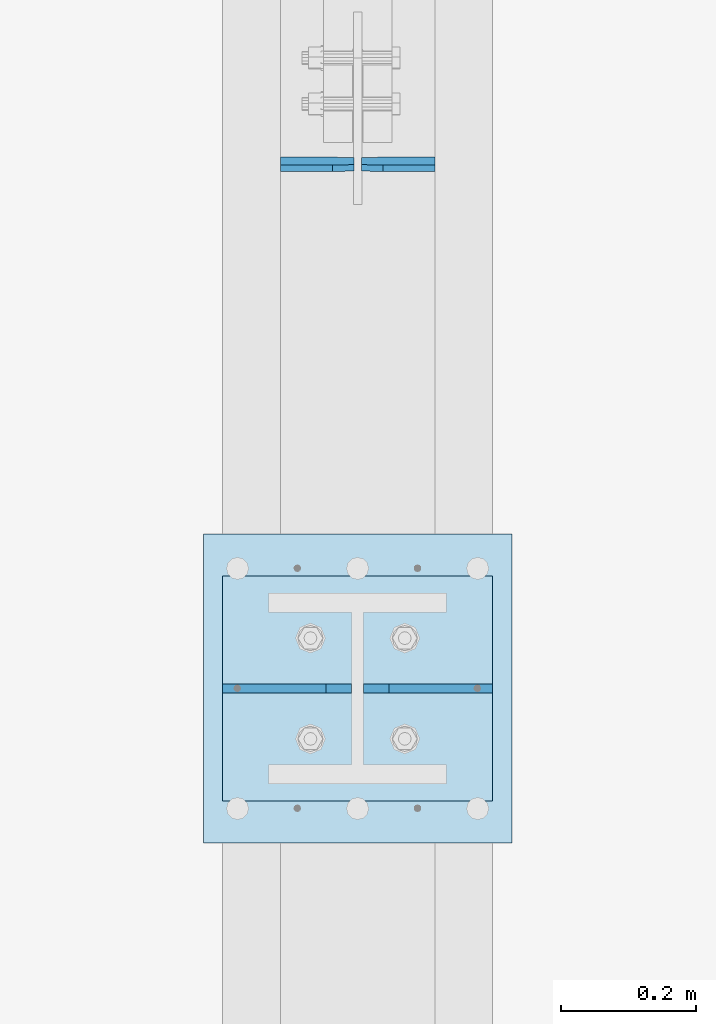
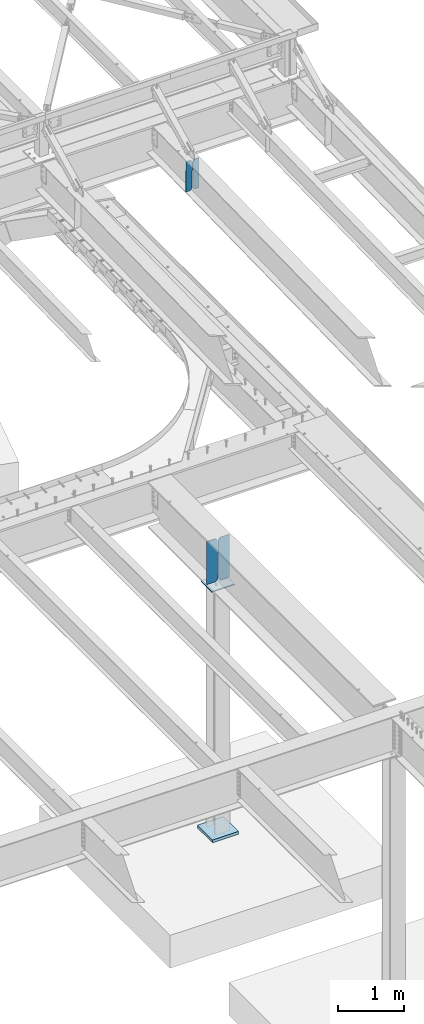
# One storey, part 1674 of 1763: 6 plates, 3 elements without a shape of their own.
"""IFC2X3 building model written with IfcOpenShell, lengths in millimetres."""

import ifcopenshell
import ifcopenshell.guid

model = None  # the IFC model being written
_history = None  # IfcOwnerHistory: only IFC2X3 demands one
_inside = {}  # id of a spatial element -> (the spatial element, [elements in it])
_under = {}  # id of a project, library or spatial element -> (it, [spatial elements below it])
_declared = {}  # id of a project -> (the project, [libraries it declares])
_typed = {}  # id of a type object -> (the type object, [elements of that type])
_made_of = {}  # id of a material, layer set ... -> (it, [elements and type objects made of it])


def new_model(schema):
    """Start an empty IFC model of exactly this schema.

    Asked for "IFC4X3", IfcOpenShell would pick the latest addendum, in which some entities
    have other attributes; the version numbers below select the first issue.
    IFC2X3 requires an IfcOwnerHistory on every rooted entity: one is made here for all.
    """
    global model, _history
    if schema == "IFC4X3":
        model = ifcopenshell.file(schema_version=(4, 3, 0, 0))
    else:
        model = ifcopenshell.file(schema=schema)
    _inside.clear()
    _under.clear()
    _declared.clear()
    _typed.clear()
    _made_of.clear()
    _history = None
    if model.schema == "IFC2X3":
        org = make("IfcOrganization", Name="unknown")
        user = make(
            "IfcPersonAndOrganization",
            ThePerson=make("IfcPerson", FamilyName="unknown"),
            TheOrganization=org,
        )
        app = make(
            "IfcApplication",
            ApplicationDeveloper=org,
            Version="unknown",
            ApplicationFullName="unknown",
            ApplicationIdentifier="unknown",
        )
        _history = make(
            "IfcOwnerHistory",
            OwningUser=user,
            OwningApplication=app,
            ChangeAction="ADDED",
            CreationDate=0,
        )
    return model


def make(cls, **values):
    """One entity of the class cls with the attributes given. An attribute that is None is left unset."""
    return model.create_entity(
        cls, **{name: value for name, value in values.items() if value is not None}
    )


def rooted(cls, **values):
    """An entity with a GlobalId (a new one), such as an element, a storey or a relation."""
    return make(cls, GlobalId=ifcopenshell.guid.new(), OwnerHistory=_history, **values)


def si_unit(unit_type, name, prefix=None):
    """IfcSIUnit, for example si_unit("LENGTHUNIT", "METRE", prefix="MILLI")."""
    return make("IfcSIUnit", UnitType=unit_type, Prefix=prefix, Name=name)


def assignment(units):
    """IfcUnitAssignment: the units of a project."""
    return None if units is None else make("IfcUnitAssignment", Units=units)


def point(xyz):
    """IfcCartesianPoint."""
    return None if xyz is None else make("IfcCartesianPoint", Coordinates=xyz)


def direction(xyz):
    """IfcDirection."""
    return None if xyz is None else make("IfcDirection", DirectionRatios=xyz)


def frame(location, z_axis=None, x_axis=None):
    """IfcAxis2Placement3D, a coordinate frame: its origin and axes. An axis left out is left unset."""
    return make(
        "IfcAxis2Placement3D",
        Location=point(location),
        Axis=direction(z_axis),
        RefDirection=direction(x_axis),
    )


def origin_with_axes():
    """The frame at (0, 0, 0) with the z axis (0, 0, 1) and the x axis (1, 0, 0) written out."""
    return frame((0.0, 0.0, 0.0), z_axis=(0.0, 0.0, 1.0), x_axis=(1.0, 0.0, 0.0))


def place(relative_to, where):
    """IfcLocalPlacement: puts the frame where relative to a parent placement (None: the world)."""
    return make(
        "IfcLocalPlacement", PlacementRelTo=relative_to, RelativePlacement=where
    )


def context(
    kind, dimensions, precision=None, world=None, true_north=None, identifier=None
):
    """IfcGeometricRepresentationContext, for example the 3D "Model" context."""
    return make(
        "IfcGeometricRepresentationContext",
        ContextIdentifier=identifier,
        ContextType=kind,
        CoordinateSpaceDimension=dimensions,
        Precision=precision,
        WorldCoordinateSystem=world,
        TrueNorth=true_north,
    )


def subcontext(parent, identifier, kind, view, scale=None):
    """IfcGeometricRepresentationSubContext, for example "Body" below "Model"."""
    return make(
        "IfcGeometricRepresentationSubContext",
        ContextIdentifier=identifier,
        ContextType=kind,
        ParentContext=parent,
        TargetScale=scale,
        TargetView=view,
    )


def project(units=None, contexts=None):
    """IfcProject with its units and contexts."""
    return rooted(
        "IfcProject",
        Name="project",
        RepresentationContexts=contexts,
        UnitsInContext=assignment(units),
    )


def spatial(cls, under=None, at=None, **own):
    """A site, building, storey or space (cls), placed at a placement, below another one or the project."""
    s = rooted(cls, ObjectPlacement=at, **own)
    if under is not None:
        _under.setdefault(under.id(), (under, []))[1].append(s)
    return s


def faces_of(points, faces, orient=None, outer=None):
    """IfcFace entities. A face is a list of loops; a loop is a list of indices into points, from 0.

    orient and outer hold one flag for each loop. By default every Orientation is true, the
    first loop of a face is its IfcFaceOuterBound and the others are IfcFaceBound.
    """
    made = []
    for i, loops in enumerate(faces):
        bounds = []
        for j, loop in enumerate(loops):
            is_outer = j == 0 if outer is None else outer[i][j]
            bounds.append(
                make(
                    "IfcFaceOuterBound" if is_outer else "IfcFaceBound",
                    Bound=make("IfcPolyLoop", Polygon=[points[k] for k in loop]),
                    Orientation=True if orient is None else orient[i][j],
                )
            )
        made.append(make("IfcFace", Bounds=bounds))
    return made


def faceted_brep(points, faces, orient=None, outer=None, voids=None):
    """IfcFacetedBrep: a solid bounded by flat faces; with voids (closed shells), ...WithVoids."""
    shared = [point(p) for p in points]
    hull = make("IfcClosedShell", CfsFaces=faces_of(shared, faces, orient, outer))
    if voids is None:
        return make("IfcFacetedBrep", Outer=hull)
    return make(
        "IfcFacetedBrepWithVoids",
        Outer=hull,
        Voids=[
            make(cls, CfsFaces=faces_of(shared, fs, o, b)) for cls, fs, o, b in voids
        ],
    )


def shape(context_of_items, identifier, shape_type, items):
    """IfcShapeRepresentation: the items that make up one representation, for example the "Body"."""
    return make(
        "IfcShapeRepresentation",
        ContextOfItems=context_of_items,
        RepresentationIdentifier=identifier,
        RepresentationType=shape_type,
        Items=items,
    )


def material(Name=None, Category=None):
    """IfcMaterial."""
    return make("IfcMaterial", Name=Name, Category=Category)


def made_of(thing, what):
    """Note that an element or type object is made of a material, layer set ...; save() writes the relation."""
    if what is not None:
        _made_of.setdefault(what.id(), (what, []))[1].append(thing)
    return thing


def type_object(cls, material=None, **own):
    """A type object (cls), such as IfcWallType, which elements share."""
    return made_of(rooted(cls, **own), material)


def element(
    cls,
    number,
    at=None,
    inside=None,
    cuts=None,
    type_object=None,
    material=None,
    context=None,
    identifier="Body",
    shape_type=None,
    held_by="IfcProductDefinitionShape",
    body=None,
    shapes=None,
    **own,
):
    """One element of the class cls, such as IfcWall. Its Tag is "e" and its number.

    at: its placement. inside: the storey or other place that contains it. cuts: it is an
    opening in that element (IfcRelVoidsElement). A single representation is given by context,
    identifier, shape_type and body (its items); several are given by shapes. held_by: the class
    of the entity that holds the representations. save() writes the other relations.
    """
    e = rooted(cls, Tag="e%d" % number, ObjectPlacement=at, **own)
    if body is not None:
        shapes = [shape(context, identifier, shape_type, body)]
    if shapes is not None:
        e.Representation = make(held_by, Representations=shapes)
    if inside is not None:
        _inside.setdefault(inside.id(), (inside, []))[1].append(e)
    if cuts is not None:
        rooted(
            "IfcRelVoidsElement", RelatingBuildingElement=cuts, RelatedOpeningElement=e
        )
    if type_object is not None:
        _typed.setdefault(type_object.id(), (type_object, []))[1].append(e)
    return made_of(e, material)


def aggregate(whole, parts):
    """IfcRelAggregates: a whole, such as a stair, and the parts it consists of."""
    return rooted("IfcRelAggregates", RelatingObject=whole, RelatedObjects=parts)


def save(model, path):
    """Write the relations noted so far, then the file.

    IfcRelAggregates (storeys below a building ...), IfcRelContainedInSpatialStructure (elements
    in a storey), IfcRelDefinesByType, IfcRelAssociatesMaterial and IfcRelDeclares: one each for
    every whole, place, type object, material and project.
    """
    for whole, parts in _under.values():
        aggregate(whole, parts)
    for where, things in _inside.values():
        rooted(
            "IfcRelContainedInSpatialStructure",
            RelatedElements=things,
            RelatingStructure=where,
        )
    for kind, things in _typed.values():
        rooted("IfcRelDefinesByType", RelatedObjects=things, RelatingType=kind)
    for what, things in _made_of.values():
        rooted("IfcRelAssociatesMaterial", RelatedObjects=things, RelatingMaterial=what)
    for by, libraries in _declared.values():
        rooted("IfcRelDeclares", RelatingContext=by, RelatedDefinitions=libraries)
    model.write(path)


model = new_model("IFC2X3")

# Units and contexts
model_context = context("Model", 3, precision=1e-05, world=origin_with_axes())
body_context = subcontext(model_context, "Body", "Model", "MODEL_VIEW")
ifc_project = project(units=[si_unit("LENGTHUNIT", "METRE", prefix="MILLI"), si_unit("AREAUNIT", "SQUARE_METRE"), si_unit("VOLUMEUNIT", "CUBIC_METRE"), si_unit("MASSUNIT", "GRAM", prefix="KILO"), si_unit("TIMEUNIT", "SECOND"), si_unit("PLANEANGLEUNIT", "RADIAN"), si_unit("SOLIDANGLEUNIT", "STERADIAN"), si_unit("THERMODYNAMICTEMPERATUREUNIT", "DEGREE_CELSIUS"), si_unit("LUMINOUSINTENSITYUNIT", "LUMEN")], contexts=[model_context])

# Site, building, storey
site_placement = place(None, origin_with_axes())
site = spatial("IfcSite", under=ifc_project, at=site_placement, CompositionType="ELEMENT")
building_placement = place(site_placement, origin_with_axes())
building = spatial("IfcBuilding", under=site, at=building_placement, Name="Undefined", CompositionType="ELEMENT")
storey_placement = place(building_placement, origin_with_axes())
storey = spatial("IfcBuildingStorey", under=building, at=storey_placement, Name="Undefined", CompositionType="ELEMENT", Elevation=0.0)

# Assembly, plates
assembly_1_placement = place(storey_placement, origin_with_axes())
assembly_1 = element("IfcElementAssembly", 1, at=assembly_1_placement, inside=storey, Name="BEAM", AssemblyPlace="NOTDEFINED", PredefinedType="RIGID_FRAME")
ifc_material_1 = material(Name="STEEL/A36")
plate_type_1 = type_object("IfcPlateType", PredefinedType="NOTDEFINED")
plate_1_placement = place(assembly_1_placement, frame((-23913.5372736984, 50921.7749258593, 11135.191873926), z_axis=(0.0, -0.0206852279954837, 0.999786037781472), x_axis=(-1.0, 0.0, 0.0)))
plate_1 = element("IfcPlate", 2, at=plate_1_placement, type_object=plate_type_1, material=ifc_material_1, Name="PLATE", context=body_context, shape_type="Brep", body=[
    faceted_brep([(0.0, -4.76249999999982, 0.0), (0.0, -4.76250000012806, 568.325012206604), (0.0, 4.7624999999025, 568.325012206606), (0.0, 4.76249999999982, 0.0), (76.9937515258789, -4.76250000012806, 568.325012206604), (76.9937515258789, 4.7624999999025, 568.325012206606), (108.743751525879, -4.76250000012078, 536.575012206626), (108.743751525879, 4.76249999990978, 536.575012206629), (108.743751525879, -4.76250000001892, 31.7499999999764), (108.743751525879, 4.76250000000437, 31.7499999999782), (76.9937515258789, -4.76250000001892, -1.81898940354586e-12), (76.9937515258789, 4.76250000001164, 3.63797880709171e-12)], [[[0, 1, 2, 3]], [[1, 4, 5, 2]], [[4, 6, 7, 5]], [[6, 8, 9, 7]], [[8, 10, 11, 9]], [[10, 0, 3, 11]], [[5, 7, 9, 11, 3, 2]], [[10, 8, 6, 4, 1, 0]]]),
])
plate_2_placement = place(assembly_1_placement, frame((-24033.3935236984, 50921.7749258593, 11135.191873926), z_axis=(0.0, -0.0206852279954837, 0.999786037781472), x_axis=(-1.0, 0.0, 0.0)))
plate_2 = element("IfcPlate", 3, at=plate_2_placement, type_object=plate_type_1, material=ifc_material_1, Name="PLATE", context=body_context, shape_type="Brep", body=[
    faceted_brep([(0.0, -4.76250000000073, 31.75), (0.0, -4.76250000012078, 536.575012206626), (0.0, 4.76249999990978, 536.575012206629), (0.0, 4.76250000000073, 31.75), (31.75, -4.76250000012806, 568.325012206604), (31.75, 4.7624999999025, 568.325012206606), (108.743751525879, -4.76250000012806, 568.325012206604), (108.743751525879, 4.7624999999025, 568.325012206606), (108.743751525879, -4.76250000001892, -1.81898940354586e-12), (108.743751525879, 4.76250000001164, 3.63797880709171e-12), (31.75, -4.76250000000073, 0.0), (31.75, 4.76250000000073, 0.0)], [[[0, 1, 2, 3]], [[1, 4, 5, 2]], [[4, 6, 7, 5]], [[6, 8, 9, 7]], [[8, 10, 11, 9]], [[10, 0, 3, 11]], [[5, 7, 9, 11, 3, 2]], [[10, 8, 6, 4, 1, 0]]]),
])
aggregate(assembly_1, [plate_1, plate_2])

assembly_2_placement = place(storey_placement, origin_with_axes())
assembly_2 = element("IfcElementAssembly", 4, at=assembly_2_placement, inside=storey, Name="BEAM", AssemblyPlace="NOTDEFINED", PredefinedType="RIGID_FRAME")
ifc_material_2 = material(Name="STEEL/A572-50")
plate_type_2 = type_object("IfcPlateType", PredefinedType="NOTDEFINED")
plate_3_placement = place(assembly_2_placement, frame((-23827.8122736984, 50139.6, 5164.1375), z_axis=(0.0, 0.0, -1.0), x_axis=(-1.0, 0.0, 0.0)))
plate_3 = element("IfcPlate", 5, at=plate_3_placement, type_object=plate_type_2, material=ifc_material_2, Name="PLATE", context=body_context, shape_type="Brep", body=[
    faceted_brep([(0.0, -6.34999999999491, 1.45519152283669e-11), (0.0, -6.34999999999854, 793.75), (0.0, 6.34999999999854, 793.75), (0.0, 6.34999999999491, -2.91038304567337e-11), (153.193748474121, -6.34999999999854, 793.75), (153.193748474121, 6.34999999999854, 793.75), (191.293746948242, -6.34999999999854, 755.650001525879), (191.293746948242, 6.34999999999854, 755.650001525879), (191.293746948242, -6.34999999999854, 38.0999984741211), (191.293746948242, 6.34999999999854, 38.0999984741211), (153.193748474121, -6.34999999999854, 0.0), (153.193748474121, 6.34999999999854, 0.0)], [[[0, 1, 2, 3]], [[1, 4, 5, 2]], [[4, 6, 7, 5]], [[6, 8, 9, 7]], [[8, 10, 11, 9]], [[10, 0, 3, 11]], [[5, 7, 9, 11, 3, 2]], [[10, 8, 6, 4, 1, 0]]]),
])
plate_4_placement = place(assembly_2_placement, frame((-24227.8622736984, 50139.6, 5164.1375), z_axis=(0.0, 0.0, -1.0), x_axis=(1.0, 0.0, 0.0)))
plate_4 = element("IfcPlate", 6, at=plate_4_placement, type_object=plate_type_2, material=ifc_material_2, Name="PLATE", context=body_context, shape_type="Brep", body=[
    faceted_brep([(0.0, -6.34999999999491, 1.45519152283669e-11), (0.0, -6.34999999999854, 793.75), (0.0, 6.34999999999854, 793.75), (0.0, 6.34999999999491, -2.91038304567337e-11), (153.193748474121, -6.34999999999854, 793.75), (153.193748474121, 6.34999999999854, 793.75), (191.293746948242, -6.34999999999854, 755.650001525879), (191.293746948242, 6.34999999999854, 755.650001525879), (191.293746948242, -6.34999999999854, 38.0999984741211), (191.293746948242, 6.34999999999854, 38.0999984741211), (153.193748474121, -6.34999999999854, 0.0), (153.193748474121, 6.34999999999854, 0.0)], [[[0, 1, 2, 3]], [[1, 4, 5, 2]], [[4, 6, 7, 5]], [[6, 8, 9, 7]], [[8, 10, 11, 9]], [[10, 0, 3, 11]], [[5, 7, 9, 11, 3, 2]], [[10, 8, 6, 4, 1, 0]]]),
])
aggregate(assembly_2, [plate_3, plate_4])

assembly_3_placement = place(storey_placement, origin_with_axes())
assembly_3 = element("IfcElementAssembly", 7, at=assembly_3_placement, inside=storey, Name="COLUMN", AssemblyPlace="NOTDEFINED", PredefinedType="RIGID_FRAME")
plate_type_3 = type_object("IfcPlateType", PredefinedType="NOTDEFINED")
plate_5_placement = place(assembly_3_placement, frame((-23827.8122736984, 49972.9125, 4330.7), z_axis=(0.0, 1.0, 0.0), x_axis=(-1.0, 0.0, 0.0)))
plate_5 = element("IfcPlate", 8, at=plate_5_placement, type_object=plate_type_3, material=ifc_material_2, Name="PLATE", context=body_context, shape_type="Brep", body=[
    faceted_brep([(0.0, -9.52500000000146, 0.0), (0.0, -9.52499999999964, 333.375), (0.0, 9.52499999999964, 333.375), (0.0, 9.52500000000146, 0.0), (400.049987792969, -9.52499999999964, 333.375), (400.049987792969, 9.52499999999964, 333.375), (400.049987792969, -9.52499999999964, 0.0), (400.049987792969, 9.52499999999964, 0.0)], [[[0, 1, 2, 3]], [[1, 4, 5, 2]], [[4, 6, 7, 5]], [[6, 0, 3, 7]], [[5, 7, 3, 2]], [[6, 4, 1, 0]]]),
])
plate_type_4 = type_object("IfcPlateType", PredefinedType="NOTDEFINED")
plate_6_placement = place(assembly_3_placement, frame((-24256.4372736984, 50368.2, -241.299999999997), z_axis=(1.0, 0.0, 0.0), x_axis=(0.0, -1.0, 0.0)))
plate_6 = element("IfcPlate", 9, at=plate_6_placement, type_object=plate_type_4, material=ifc_material_1, Name="PLATE", context=body_context, shape_type="Brep", body=[
    faceted_brep([(0.0, -25.4000000000015, 0.0), (0.0, -25.4, 457.200012207031), (0.0, 25.4, 457.200012207031), (0.0, 25.4000000000015, 0.0), (457.200012207031, -25.4, 457.200012207031), (457.200012207031, 25.4, 457.200012207031), (457.200012207031, -25.4, 0.0), (457.200012207031, 25.4, 0.0)], [[[0, 1, 2, 3]], [[1, 4, 5, 2]], [[4, 6, 7, 5]], [[6, 0, 3, 7]], [[5, 7, 3, 2]], [[6, 4, 1, 0]]]),
])
aggregate(assembly_3, [plate_5, plate_6])

save(model, "model.ifc")
